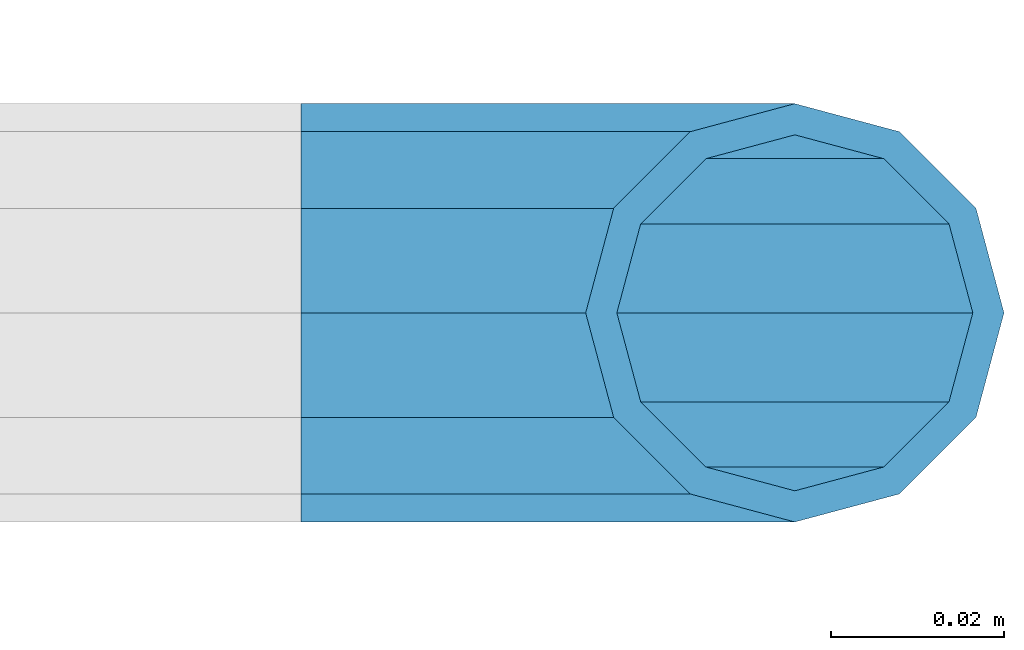
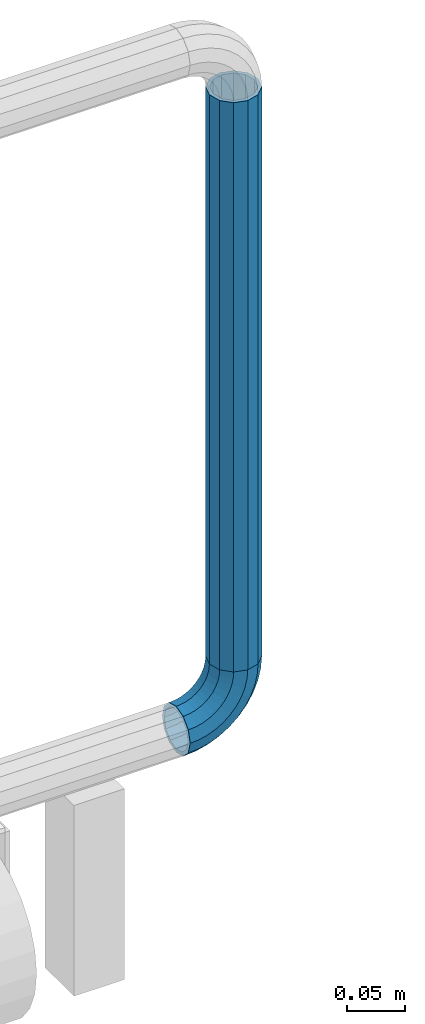
# One storey, part 175 of 240: 1 beam, 1 member.
"""IFC2X3 building model written with IfcOpenShell, lengths in millimetres."""

from ifc_helpers import new_model, si_unit, frame, origin_with_axes, place, context, subcontext, project, spatial, faceted_brep, material, type_object, element, save


model = new_model("IFC2X3")

# Units and contexts
model_context = context("Model", 3, precision=1e-05, world=origin_with_axes())
body_context = subcontext(model_context, "Body", "Model", "MODEL_VIEW")
ifc_project = project(units=[si_unit("LENGTHUNIT", "METRE", prefix="MILLI"), si_unit("AREAUNIT", "SQUARE_METRE"), si_unit("VOLUMEUNIT", "CUBIC_METRE"), si_unit("MASSUNIT", "GRAM", prefix="KILO"), si_unit("TIMEUNIT", "SECOND"), si_unit("PLANEANGLEUNIT", "RADIAN"), si_unit("SOLIDANGLEUNIT", "STERADIAN"), si_unit("THERMODYNAMICTEMPERATUREUNIT", "DEGREE_CELSIUS"), si_unit("LUMINOUSINTENSITYUNIT", "LUMEN")], contexts=[model_context])

# Site, building, storey
site_placement = place(None, origin_with_axes())
site = spatial("IfcSite", under=ifc_project, at=site_placement, CompositionType="ELEMENT")
building_placement = place(site_placement, origin_with_axes())
building = spatial("IfcBuilding", under=site, at=building_placement, Name="Standard", CompositionType="ELEMENT")
storey_placement = place(building_placement, origin_with_axes())
storey = spatial("IfcBuildingStorey", under=building, at=storey_placement, Name="Undefined", CompositionType="ELEMENT", Elevation=0.0)

# Member
ifc_material = material()
member_type = type_object("IfcMemberType", PredefinedType="NOTDEFINED")
member_placement = place(storey_placement, frame((69989.9460172356, 35941.8539999962, 281.650006544463), z_axis=(0.0, -1.0, 0.0), x_axis=(-0.707106781186548, 0.0, -0.707106781186548)))
element("IfcMember", 1, at=member_placement, inside=storey, type_object=member_type, material=ifc_material, context=body_context, shape_type="Brep", body=[
    faceted_brep([(17.0766287656515, -17.0766287656661, 0.0), (14.7887943220485, -14.788794322063, -12.0749999999971), (19.0945697419447, -11.1113146999778, -12.0749999999971), (20.9963409898191, -13.7288782624237, 0.0), (8.53831438282214, -8.53831438283669, -20.9145135013969), (13.8988340683864, -3.95999805534666, -20.9145135013969), (-7.27595761418343e-12, -7.27595761418343e-12, -24.1500000000015), (6.80132714695355, 5.80888215173036, -24.1500000000015), (-8.53831438283669, 8.53831438282214, -20.9145135013969), (-0.296179774479242, 15.5777623588074, -20.9145135013969), (-14.788794322063, 14.7887943220485, -12.0749999999971), (-5.49191544803034, 22.7290790034458, -12.0749999999971), (-17.0766287656588, 17.0766287656443, 0.0), (-7.39368669591204, 25.3466425658844, 0.0), (-14.788794322063, 14.7887943220485, 12.0749999999971), (-5.49191544803034, 22.7290790034458, 12.0749999999971), (-8.53831438283669, 8.53831438282214, 20.9145135013969), (-0.296179774479242, 15.5777623588074, 20.9145135013969), (-7.27595761418343e-12, -7.27595761418343e-12, 24.1500000000015), (6.80132714695355, 5.80888215173036, 24.1500000000015), (8.53831438282214, -8.53831438283669, 20.9145135013969), (13.8988340683864, -3.95999805534666, 20.9145135013969), (14.7887943220485, -14.788794322063, 12.0749999999971), (19.0945697419447, -11.1113146999778, 12.0749999999971), (14.5310443533745, -14.531044353389, 0.0), (12.5842535535412, -12.5842535535558, 10.2750000000015), (17.2620366843112, -8.58904933077429, 10.2750000000015), (18.8803140815653, -10.8164170826713, 0.0), (7.26552217668359, -7.26552217669814, 17.7968220477705), (12.8408206142631, -2.50376746547408, 17.7968220477705), (-7.27595761418343e-12, -7.27595761418343e-12, 20.5500000000029), (6.80132714695355, 5.80888215173036, 20.5500000000029), (-7.26552217669814, 7.26552217668359, 17.7968220477705), (0.761833679658594, 14.1215317689348, 17.7968220477705), (-12.5842535535558, 12.5842535535412, 10.2750000000015), (-3.65938239038951, 20.2068136342496, 10.2750000000015), (-14.531044353389, 14.5310443533745, 0.0), (-5.27765978765092, 22.4341813861392, 0.0), (-12.5842535535558, 12.5842535535412, -10.2750000000015), (-3.65938239038951, 20.2068136342496, -10.2750000000015), (-7.26552217669814, 7.26552217668359, -17.7968220477705), (0.761833679658594, 14.1215317689348, -17.7968220477705), (-7.27595761418343e-12, -7.27595761418343e-12, -20.5500000000029), (6.80132714695355, 5.80888215173036, -20.5500000000029), (7.26552217668359, -7.26552217669814, -17.7968220477705), (12.8408206142631, -2.50376746547408, -17.7968220477705), (12.5842535535412, -12.5842535535558, -10.2750000000015), (17.2620366843112, -8.58904933077429, -10.2750000000015), (23.922618478784, -8.15268262886093, -12.0749999999971), (25.3914986111849, -11.035522208047, 0.0), (19.9095633268225, -0.276618428477377, -20.9145135013969), (14.427628042482, 10.4822853510996, -24.1500000000015), (8.94569275811955, 21.2411891306692, -20.9145135013969), (4.93263760617265, 29.1172533310673, -12.0749999999971), (3.46375747377169, 32.0000929102534, 0.0), (4.93263760617265, 29.1172533310673, 12.0749999999971), (8.94569275811955, 21.2411891306692, 20.9145135013969), (14.427628042482, 10.4822853510996, 24.1500000000015), (19.9095633268225, -0.276618428477377, 20.9145135013969), (23.922618478784, -8.15268262886093, 12.0749999999971), (22.5072161777207, -5.37479920328769, 10.2750000000015), (23.7571328121194, -7.82789872097055, 0.0), (19.092380427297, 1.32719331506087, 17.7968220477705), (14.427628042482, 10.4822853510996, 20.5500000000029), (9.76287565764505, 19.637377387131, 17.7968220477705), (6.34803990724322, 26.3393699054868, 10.2750000000015), (5.09812327282998, 28.7924694231697, 0.0), (6.34803990724322, 26.3393699054868, -10.2750000000015), (9.76287565764505, 19.637377387131, -17.7968220477705), (14.427628042482, 10.4822853510996, -20.5500000000029), (19.092380427297, 1.32719331506087, -17.7968220477705), (22.5072161777207, -5.37479920328769, -10.2750000000015), (29.1540579492721, -5.98574944946449, -12.0749999999971), (30.153878262412, -9.06287996734318, 0.0), (26.4224980553408, 2.42112746692146, -20.9145135013969), (22.6911178482551, 13.9051349011861, -24.1500000000015), (18.9597376411839, 25.3891423354507, -20.9145135013969), (16.2281777472454, 33.7960192518294, -12.0749999999971), (15.2283574340981, 36.8731497697154, 0.0), (16.2281777472454, 33.7960192518294, 12.0749999999971), (18.9597376411839, 25.3891423354507, 20.9145135013969), (22.6911178482551, 13.9051349011861, 24.1500000000015), (26.4224980553408, 2.42112746692146, 20.9145135013969), (29.1540579492721, -5.98574944946449, 12.0749999999971), (28.1906383068854, -3.02064867669833, 10.2750000000015), (29.0414170826625, -5.63907650867623, 0.0), (25.8662674654624, 4.1330291962513, 17.7968220477705), (22.6911178482551, 13.9051349011861, 20.5500000000029), (19.515968231055, 23.6772406061136, 17.7968220477705), (17.1915973896321, 30.8309184790633, 10.2750000000015), (16.3408186138549, 33.4493463110557, 0.0), (17.1915973896321, 30.8309184790633, -10.2750000000015), (19.515968231055, 23.6772406061136, -17.7968220477705), (22.6911178482551, 13.9051349011861, -20.5500000000029), (25.8662674654624, 4.1330291962513, -17.7968220477705), (28.1906383068854, -3.02064867669833, -10.2750000000015), (34.6600727515033, -4.6638722482603, -12.0749999999971), (35.1662143510621, -7.85952453908976, 0.0), (33.277268185695, 4.06681217360165, -20.9145135013969), (31.3883220203425, 15.9931488862931, -24.1500000000015), (29.4993758549681, 27.9194855989626, -20.9145135013969), (28.116571289167, 36.6501700208319, -12.0749999999971), (27.6104296896156, 39.845822311654, 0.0), (28.116571289167, 36.6501700208319, 12.0749999999971), (29.4993758549681, 27.9194855989626, 20.9145135013969), (31.3883220203425, 15.9931488862931, 24.1500000000015), (33.277268185695, 4.06681217360165, 20.9145135013969), (34.6600727515033, -4.6638722482603, 12.0749999999971), (34.1723583567946, -1.58456474995182, 10.2750000000015), (34.6030502769136, -4.30384651295026, 0.0), (32.9956861486207, 5.8446511866714, 17.7968220477705), (31.3883220203425, 15.9931488862931, 20.5500000000029), (29.7809578920424, 26.1416465858929, 17.7968220477705), (28.6042856838831, 33.5708625225161, 10.2750000000015), (28.1735937637641, 36.2901442855145, 0.0), (28.6042856838831, 33.5708625225161, -10.2750000000015), (29.7809578920424, 26.1416465858929, -17.7968220477705), (31.3883220203425, 15.9931488862931, -20.5500000000029), (32.9956861486207, 5.8446511866714, -17.7968220477705), (34.1723583567946, -1.58456474995182, -10.2750000000015), (40.3050865276236, -4.21960002903506, -12.0749999999971), (40.3050865276236, -7.45508652764693, 0.0), (40.3050865276382, 4.61991347236471, -20.9145135013969), (40.3050865276236, 16.6949134723618, -24.1500000000015), (40.3050865276309, 28.7699134723662, -20.9145135013969), (40.3050865276309, 37.6094269737514, -12.0749999999971), (40.3050865276309, 40.8449134723633, 0.0), (40.3050865276309, 37.6094269737514, 12.0749999999971), (40.3050865276309, 28.7699134723662, 20.9145135013969), (40.3050865276236, 16.6949134723618, 24.1500000000015), (40.3050865276382, 4.61991347236471, 20.9145135013969), (40.3050865276236, -4.21960002903506, 12.0749999999971), (40.3050865276309, -1.10190857540874, 10.2750000000015), (40.3050865276309, -3.85508652763383, 0.0), (40.3050865276309, 6.41991347236035, 17.7968220477705), (40.3050865276236, 16.6949134723618, 20.5500000000029), (40.3050865276236, 26.969913472356, 17.7968220477705), (40.3050865276309, 34.4917355201324, 10.2750000000015), (40.3050865276309, 37.2449134723574, 0.0), (40.3050865276309, 34.4917355201324, -10.2750000000015), (40.3050865276236, 26.969913472356, -17.7968220477705), (40.3050865276236, 16.6949134723618, -20.5500000000029), (40.3050865276309, 6.41991347236035, -17.7968220477705), (40.3050865276309, -1.10190857540874, -10.2750000000015), (45.9501003037585, -4.6638722482603, -12.0749999999971), (45.443958704207, -7.85952453908249, 0.0), (47.3329048695668, 4.06681217360165, -20.9145135013969), (49.2218510349267, 15.9931488862858, -24.1500000000015), (51.1107972002865, 27.9194855989699, -20.9145135013969), (52.4936017660948, 36.6501700208319, -12.0749999999971), (52.9997433656463, 39.845822311654, 0.0), (52.4936017660948, 36.6501700208319, 12.0749999999971), (51.1107972002865, 27.9194855989699, 20.9145135013969), (49.2218510349267, 15.9931488862858, 24.1500000000015), (47.3329048695668, 4.06681217360165, 20.9145135013969), (45.9501003037585, -4.6638722482603, 12.0749999999971), (46.4378146984673, -1.58456474993727, 10.2750000000015), (46.007122778341, -4.30384651294298, 0.0), (47.6144869066411, 5.8446511866714, 17.7968220477705), (49.2218510349267, 15.9931488862858, 20.5500000000029), (50.8292151632122, 26.1416465859002, 17.7968220477705), (52.0058873713788, 33.5708625225161, 10.2750000000015), (52.4365792914905, 36.2901442855073, 0.0), (52.0058873713788, 33.5708625225161, -10.2750000000015), (50.8292151632122, 26.1416465859002, -17.7968220477705), (49.2218510349267, 15.9931488862858, -20.5500000000029), (47.6144869066411, 5.8446511866714, -17.7968220477705), (46.4378146984673, -1.58456474993727, -10.2750000000015), (51.4561151059825, -5.98574944945722, -12.0749999999971), (50.4562947928498, -9.06287996734318, 0.0), (54.187674999921, 2.42112746692146, -20.9145135013969), (57.9190552069995, 13.9051349011788, -24.1500000000015), (61.6504354140779, 25.3891423354507, -20.9145135013969), (64.3819953080165, 33.7960192518294, -12.0749999999971), (65.3818156211564, 36.8731497697081, 0.0), (64.3819953080165, 33.7960192518294, 12.0749999999971), (61.6504354140779, 25.3891423354507, 20.9145135013969), (57.9190552069995, 13.9051349011788, 24.1500000000015), (54.187674999921, 2.42112746692146, 20.9145135013969), (51.4561151059825, -5.98574944945722, 12.0749999999971), (52.4195347483765, -3.02064867668378, 10.2750000000015), (51.5687559725993, -5.63907650867623, 0.0), (54.7439055897994, 4.1330291962513, 17.7968220477705), (57.9190552069995, 13.9051349011788, 20.5500000000029), (61.0942048242068, 23.6772406061282, 17.7968220477705), (63.4185756656298, 30.8309184790633, 10.2750000000015), (64.2693544414069, 33.4493463110557, 0.0), (63.4185756656298, 30.8309184790633, -10.2750000000015), (61.0942048242068, 23.6772406061282, -17.7968220477705), (57.9190552069995, 13.9051349011788, -20.5500000000029), (54.7439055897994, 4.1330291962513, -17.7968220477705), (52.4195347483765, -3.02064867668378, -10.2750000000015), (56.6875545764706, -8.15268262886821, -12.0749999999971), (55.2186744440769, -11.035522208047, 0.0), (60.700609728432, -0.276618428470101, -20.9145135013969), (66.1825450127799, 10.4822853510996, -24.1500000000015), (71.6644802971277, 21.2411891306692, -20.9145135013969), (75.6775354490892, 29.1172533310673, -12.0749999999971), (77.1464155814901, 32.0000929102389, 0.0), (75.6775354490892, 29.1172533310673, 12.0749999999971), (71.6644802971277, 21.2411891306692, 20.9145135013969), (66.1825450127799, 10.4822853510996, 24.1500000000015), (60.700609728432, -0.276618428470101, 20.9145135013969), (56.6875545764706, -8.15268262886821, 12.0749999999971), (58.1029568775411, -5.37479920328769, 10.2750000000015), (56.8530402431425, -7.82789872097055, 0.0), (61.5177926279575, 1.32719331506814, 17.7968220477705), (66.1825450127799, 10.4822853510996, 20.5500000000029), (70.8472973976022, 19.637377387131, 17.7968220477705), (74.2621331480259, 26.3393699054795, 10.2750000000015), (75.5120497824319, 28.7924694231697, 0.0), (74.2621331480259, 26.3393699054795, -10.2750000000015), (70.8472973976022, 19.637377387131, -17.7968220477705), (66.1825450127799, 10.4822853510996, -20.5500000000029), (61.5177926279575, 1.32719331506814, -17.7968220477705), (58.1029568775411, -5.37479920328769, -10.2750000000015), (61.5156033133026, -11.1113146999778, -12.0749999999971), (59.6138320654354, -13.7288782624164, 0.0), (66.7113389868682, -3.95999805533938, -20.9145135013969), (73.808845908301, 5.80888215173763, -24.1500000000015), (80.9063528297338, 15.5777623588147, -20.9145135013969), (86.1020885032849, 22.7290790034385, -12.0749999999971), (88.0038597511593, 25.3466425658844, 0.0), (86.1020885032849, 22.7290790034385, 12.0749999999971), (80.9063528297338, 15.5777623588147, 20.9145135013969), (73.808845908301, 5.80888215173763, 24.1500000000015), (66.7113389868682, -3.95999805533938, 20.9145135013969), (61.5156033133026, -11.1113146999778, 12.0749999999971), (63.3481363709434, -8.58904933078156, 10.2750000000015), (61.7298589736965, -10.8164170826713, 0.0), (67.7693524409915, -2.50376746546681, 17.7968220477705), (73.808845908301, 5.80888215173763, 20.5500000000029), (79.8483393756032, 14.1215317689348, 17.7968220477705), (84.2695554456513, 20.2068136342496, 10.2750000000015), (85.8878328429128, 22.4341813861392, 0.0), (84.2695554456513, 20.2068136342496, -10.2750000000015), (79.8483393756032, 14.1215317689348, -17.7968220477705), (73.808845908301, 5.80888215173763, -20.5500000000029), (67.7693524409915, -2.50376746546681, -17.7968220477705), (63.3481363709434, -8.58904933078156, -10.2750000000015), (65.8213787332061, -14.7887943220558, -12.0749999999971), (63.5335442896103, -17.0766287656515, 0.0), (72.0718586724324, -8.53831438282941, -20.9145135013969), (80.6101730552618, 0.0, -24.1500000000015), (89.148487438084, 8.53831438282214, -20.9145135013969), (95.3989673773176, 14.7887943220558, -12.0749999999971), (97.6868018209134, 17.0766287656515, 0.0), (95.3989673773176, 14.7887943220558, 12.0749999999971), (89.148487438084, 8.53831438282214, 20.9145135013969), (80.6101730552618, 0.0, 24.1500000000015), (72.0718586724324, -8.53831438282941, 20.9145135013969), (65.8213787332061, -14.7887943220558, 12.0749999999971), (68.0259195017134, -12.5842535535485, 10.2750000000015), (66.0791287018728, -14.531044353389, 0.0), (73.344650878571, -7.26552217669087, 17.7968220477705), (80.6101730552618, 0.0, 20.5500000000029), (87.8756952319454, 7.26552217668359, 17.7968220477705), (93.194426608803, 12.5842535535412, 10.2750000000015), (95.1412174086436, 14.5310443533817, 0.0), (93.194426608803, 12.5842535535412, -10.2750000000015), (87.8756952319454, 7.26552217668359, -17.7968220477705), (80.6101730552618, 0.0, -20.5500000000029), (73.344650878571, -7.26552217669087, -17.7968220477705), (68.0259195017134, -12.5842535535485, -10.2750000000015)], [[[0, 1, 2, 3]], [[1, 4, 5, 2]], [[4, 6, 7, 5]], [[6, 8, 9, 7]], [[8, 10, 11, 9]], [[10, 12, 13, 11]], [[12, 14, 15, 13]], [[14, 16, 17, 15]], [[16, 18, 19, 17]], [[18, 20, 21, 19]], [[20, 22, 23, 21]], [[22, 0, 3, 23]], [[24, 25, 26, 27]], [[25, 28, 29, 26]], [[28, 30, 31, 29]], [[30, 32, 33, 31]], [[32, 34, 35, 33]], [[34, 36, 37, 35]], [[36, 38, 39, 37]], [[38, 40, 41, 39]], [[40, 42, 43, 41]], [[42, 44, 45, 43]], [[44, 46, 47, 45]], [[46, 24, 27, 47]], [[22, 20, 18, 16, 14, 12, 10, 8, 6, 4, 1, 0], [46, 44, 42, 40, 38, 36, 34, 32, 30, 28, 25, 24]], [[3, 2, 48, 49]], [[2, 5, 50, 48]], [[5, 7, 51, 50]], [[7, 9, 52, 51]], [[9, 11, 53, 52]], [[11, 13, 54, 53]], [[13, 15, 55, 54]], [[15, 17, 56, 55]], [[17, 19, 57, 56]], [[19, 21, 58, 57]], [[21, 23, 59, 58]], [[23, 3, 49, 59]], [[27, 26, 60, 61]], [[26, 29, 62, 60]], [[29, 31, 63, 62]], [[31, 33, 64, 63]], [[33, 35, 65, 64]], [[35, 37, 66, 65]], [[37, 39, 67, 66]], [[39, 41, 68, 67]], [[41, 43, 69, 68]], [[43, 45, 70, 69]], [[45, 47, 71, 70]], [[47, 27, 61, 71]], [[49, 48, 72, 73]], [[48, 50, 74, 72]], [[50, 51, 75, 74]], [[51, 52, 76, 75]], [[52, 53, 77, 76]], [[53, 54, 78, 77]], [[54, 55, 79, 78]], [[55, 56, 80, 79]], [[56, 57, 81, 80]], [[57, 58, 82, 81]], [[58, 59, 83, 82]], [[59, 49, 73, 83]], [[61, 60, 84, 85]], [[60, 62, 86, 84]], [[62, 63, 87, 86]], [[63, 64, 88, 87]], [[64, 65, 89, 88]], [[65, 66, 90, 89]], [[66, 67, 91, 90]], [[67, 68, 92, 91]], [[68, 69, 93, 92]], [[69, 70, 94, 93]], [[70, 71, 95, 94]], [[71, 61, 85, 95]], [[73, 72, 96, 97]], [[72, 74, 98, 96]], [[74, 75, 99, 98]], [[75, 76, 100, 99]], [[76, 77, 101, 100]], [[77, 78, 102, 101]], [[78, 79, 103, 102]], [[79, 80, 104, 103]], [[80, 81, 105, 104]], [[81, 82, 106, 105]], [[82, 83, 107, 106]], [[83, 73, 97, 107]], [[85, 84, 108, 109]], [[84, 86, 110, 108]], [[86, 87, 111, 110]], [[87, 88, 112, 111]], [[88, 89, 113, 112]], [[89, 90, 114, 113]], [[90, 91, 115, 114]], [[91, 92, 116, 115]], [[92, 93, 117, 116]], [[93, 94, 118, 117]], [[94, 95, 119, 118]], [[95, 85, 109, 119]], [[97, 96, 120, 121]], [[96, 98, 122, 120]], [[98, 99, 123, 122]], [[99, 100, 124, 123]], [[100, 101, 125, 124]], [[101, 102, 126, 125]], [[102, 103, 127, 126]], [[103, 104, 128, 127]], [[104, 105, 129, 128]], [[105, 106, 130, 129]], [[106, 107, 131, 130]], [[107, 97, 121, 131]], [[109, 108, 132, 133]], [[108, 110, 134, 132]], [[110, 111, 135, 134]], [[111, 112, 136, 135]], [[112, 113, 137, 136]], [[113, 114, 138, 137]], [[114, 115, 139, 138]], [[115, 116, 140, 139]], [[116, 117, 141, 140]], [[117, 118, 142, 141]], [[118, 119, 143, 142]], [[119, 109, 133, 143]], [[121, 120, 144, 145]], [[120, 122, 146, 144]], [[122, 123, 147, 146]], [[123, 124, 148, 147]], [[124, 125, 149, 148]], [[125, 126, 150, 149]], [[126, 127, 151, 150]], [[127, 128, 152, 151]], [[128, 129, 153, 152]], [[129, 130, 154, 153]], [[130, 131, 155, 154]], [[131, 121, 145, 155]], [[133, 132, 156, 157]], [[132, 134, 158, 156]], [[134, 135, 159, 158]], [[135, 136, 160, 159]], [[136, 137, 161, 160]], [[137, 138, 162, 161]], [[138, 139, 163, 162]], [[139, 140, 164, 163]], [[140, 141, 165, 164]], [[141, 142, 166, 165]], [[142, 143, 167, 166]], [[143, 133, 157, 167]], [[145, 144, 168, 169]], [[144, 146, 170, 168]], [[146, 147, 171, 170]], [[147, 148, 172, 171]], [[148, 149, 173, 172]], [[149, 150, 174, 173]], [[150, 151, 175, 174]], [[151, 152, 176, 175]], [[152, 153, 177, 176]], [[153, 154, 178, 177]], [[154, 155, 179, 178]], [[155, 145, 169, 179]], [[157, 156, 180, 181]], [[156, 158, 182, 180]], [[158, 159, 183, 182]], [[159, 160, 184, 183]], [[160, 161, 185, 184]], [[161, 162, 186, 185]], [[162, 163, 187, 186]], [[163, 164, 188, 187]], [[164, 165, 189, 188]], [[165, 166, 190, 189]], [[166, 167, 191, 190]], [[167, 157, 181, 191]], [[169, 168, 192, 193]], [[168, 170, 194, 192]], [[170, 171, 195, 194]], [[171, 172, 196, 195]], [[172, 173, 197, 196]], [[173, 174, 198, 197]], [[174, 175, 199, 198]], [[175, 176, 200, 199]], [[176, 177, 201, 200]], [[177, 178, 202, 201]], [[178, 179, 203, 202]], [[179, 169, 193, 203]], [[181, 180, 204, 205]], [[180, 182, 206, 204]], [[182, 183, 207, 206]], [[183, 184, 208, 207]], [[184, 185, 209, 208]], [[185, 186, 210, 209]], [[186, 187, 211, 210]], [[187, 188, 212, 211]], [[188, 189, 213, 212]], [[189, 190, 214, 213]], [[190, 191, 215, 214]], [[191, 181, 205, 215]], [[193, 192, 216, 217]], [[192, 194, 218, 216]], [[194, 195, 219, 218]], [[195, 196, 220, 219]], [[196, 197, 221, 220]], [[197, 198, 222, 221]], [[198, 199, 223, 222]], [[199, 200, 224, 223]], [[200, 201, 225, 224]], [[201, 202, 226, 225]], [[202, 203, 227, 226]], [[203, 193, 217, 227]], [[205, 204, 228, 229]], [[204, 206, 230, 228]], [[206, 207, 231, 230]], [[207, 208, 232, 231]], [[208, 209, 233, 232]], [[209, 210, 234, 233]], [[210, 211, 235, 234]], [[211, 212, 236, 235]], [[212, 213, 237, 236]], [[213, 214, 238, 237]], [[214, 215, 239, 238]], [[215, 205, 229, 239]], [[217, 216, 240, 241]], [[216, 218, 242, 240]], [[218, 219, 243, 242]], [[219, 220, 244, 243]], [[220, 221, 245, 244]], [[221, 222, 246, 245]], [[222, 223, 247, 246]], [[223, 224, 248, 247]], [[224, 225, 249, 248]], [[225, 226, 250, 249]], [[226, 227, 251, 250]], [[227, 217, 241, 251]], [[229, 228, 252, 253]], [[228, 230, 254, 252]], [[230, 231, 255, 254]], [[231, 232, 256, 255]], [[232, 233, 257, 256]], [[233, 234, 258, 257]], [[234, 235, 259, 258]], [[235, 236, 260, 259]], [[236, 237, 261, 260]], [[237, 238, 262, 261]], [[238, 239, 263, 262]], [[239, 229, 253, 263]], [[242, 243, 244, 245, 246, 247, 248, 249, 250, 251, 241, 240], [254, 255, 256, 257, 258, 259, 260, 261, 262, 263, 253, 252]]]),
])

# Beam
beam_type = type_object("IfcBeamType", PredefinedType="NOTDEFINED")
beam_placement = place(storey_placement, frame((69989.9460172356, 35941.8539999962, 878.350006544462), z_axis=(1.0, 0.0, 0.0), x_axis=(0.0, 0.0, -1.0)))
element("IfcBeam", 2, at=beam_placement, inside=storey, type_object=beam_type, material=ifc_material, context=body_context, shape_type="Brep", body=[
    faceted_brep([(0.0, -20.5500000000029, 0.0), (0.0, -17.7968220477705, 10.2749999999942), (596.700000000001, -17.7968220477705, 10.2749999999942), (596.700000000001, -20.5500000000029, 0.0), (0.0, -10.2750000000015, 17.7968220477633), (596.700000000001, -10.2750000000015, 17.7968220477633), (-7.27595761418343e-12, -7.27595761418343e-12, 20.5500000000029), (596.700000000001, 0.0, 20.5500000000029), (0.0, 10.2750000000015, 17.7968220477633), (596.700000000001, 10.2750000000015, 17.7968220477633), (0.0, 17.7968220477705, 10.2749999999942), (596.700000000001, 17.7968220477705, 10.2749999999942), (0.0, 20.5500000000029, 0.0), (596.700000000001, 20.5500000000029, 0.0), (0.0, 17.7968220477705, -10.2749999999942), (596.700000000001, 17.7968220477705, -10.2749999999942), (0.0, 10.2750000000015, -17.7968220477633), (596.700000000001, 10.2750000000015, -17.7968220477633), (-7.27595761418343e-12, -7.27595761418343e-12, -20.5500000000029), (596.700000000001, 0.0, -20.5500000000029), (0.0, -10.2750000000015, -17.7968220477633), (596.700000000001, -10.2750000000015, -17.7968220477633), (0.0, -17.7968220477705, -10.2749999999942), (596.700000000001, -17.7968220477705, -10.2749999999942), (0.0, -24.1500000000015, 0.0), (0.0, -20.9145135013969, -12.0749999999971), (596.700000000001, -20.9145135013969, -12.0749999999971), (596.700000000001, -24.1500000000015, 0.0), (0.0, -12.0749999999971, -20.9145135013969), (596.700000000001, -12.0749999999971, -20.9145135013969), (-7.27595761418343e-12, -7.27595761418343e-12, -24.1500000000015), (596.700000000001, 0.0, -24.1499999999942), (0.0, 12.0749999999971, -20.9145135013969), (596.700000000001, 12.0749999999971, -20.9145135013969), (0.0, 20.9145135013969, -12.0749999999971), (596.700000000001, 20.9145135013969, -12.0749999999971), (0.0, 24.1500000000015, 0.0), (596.700000000001, 24.1500000000015, 0.0), (0.0, 20.9145135013969, 12.0749999999971), (596.700000000001, 20.9145135013969, 12.0749999999971), (0.0, 12.0749999999971, 20.9145135013969), (596.700000000001, 12.0749999999971, 20.9145135013969), (-7.27595761418343e-12, -7.27595761418343e-12, 24.1500000000015), (596.700000000001, 0.0, 24.1499999999942), (0.0, -12.0749999999971, 20.9145135013969), (596.700000000001, -12.0749999999971, 20.9145135013969), (0.0, -20.9145135013969, 12.0749999999971), (596.700000000001, -20.9145135013969, 12.0749999999971)], [[[0, 1, 2, 3]], [[1, 4, 5, 2]], [[4, 6, 7, 5]], [[6, 8, 9, 7]], [[8, 10, 11, 9]], [[10, 12, 13, 11]], [[12, 14, 15, 13]], [[14, 16, 17, 15]], [[16, 18, 19, 17]], [[18, 20, 21, 19]], [[20, 22, 23, 21]], [[22, 0, 3, 23]], [[24, 25, 26, 27]], [[25, 28, 29, 26]], [[28, 30, 31, 29]], [[30, 32, 33, 31]], [[32, 34, 35, 33]], [[34, 36, 37, 35]], [[36, 38, 39, 37]], [[38, 40, 41, 39]], [[40, 42, 43, 41]], [[42, 44, 45, 43]], [[44, 46, 47, 45]], [[46, 24, 27, 47]], [[29, 31, 33, 35, 37, 39, 41, 43, 45, 47, 27, 26], [5, 7, 9, 11, 13, 15, 17, 19, 21, 23, 3, 2]], [[46, 44, 42, 40, 38, 36, 34, 32, 30, 28, 25, 24], [22, 20, 18, 16, 14, 12, 10, 8, 6, 4, 1, 0]]]),
])

save(model, "model.ifc")
